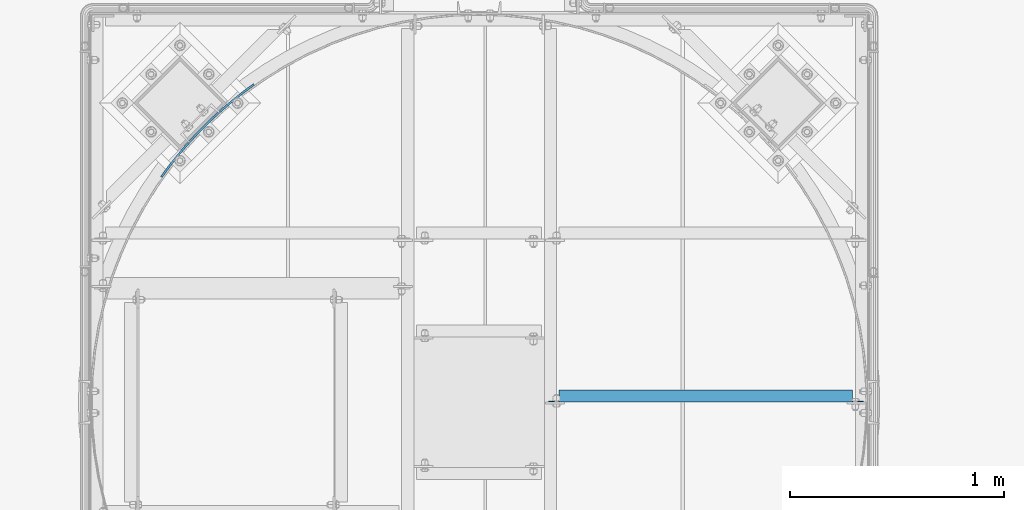
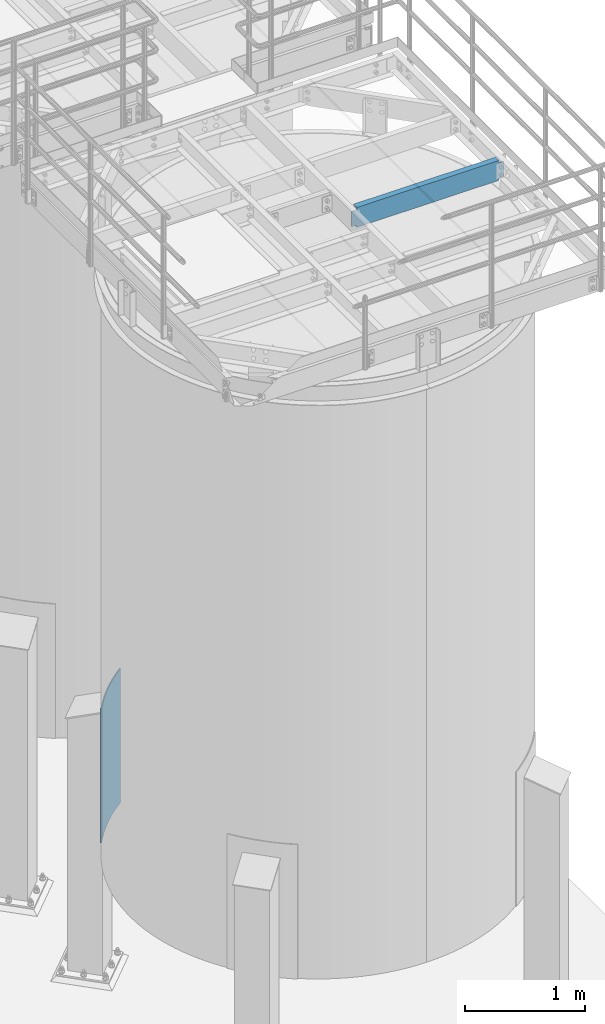
# One storey, part 922 of 1876: 2 beams, 2 elements without a shape of their own.
"""IFC2X3 building model written with IfcOpenShell, lengths in millimetres."""

from ifc_helpers import new_model, si_unit, frame, origin_with_axes, place, context, subcontext, project, spatial, faceted_brep, material, type_object, element, aggregate, save


model = new_model("IFC2X3")

# Units and contexts
model_context = context("Model", 3, precision=1e-05, world=origin_with_axes())
body_context = subcontext(model_context, "Body", "Model", "MODEL_VIEW")
ifc_project = project(units=[si_unit("LENGTHUNIT", "METRE", prefix="MILLI"), si_unit("AREAUNIT", "SQUARE_METRE"), si_unit("VOLUMEUNIT", "CUBIC_METRE"), si_unit("MASSUNIT", "GRAM", prefix="KILO"), si_unit("TIMEUNIT", "SECOND"), si_unit("PLANEANGLEUNIT", "RADIAN"), si_unit("SOLIDANGLEUNIT", "STERADIAN"), si_unit("THERMODYNAMICTEMPERATUREUNIT", "DEGREE_CELSIUS"), si_unit("LUMINOUSINTENSITYUNIT", "LUMEN")], contexts=[model_context])

# Site, building, storey
site_placement = place(None, origin_with_axes())
site = spatial("IfcSite", under=ifc_project, at=site_placement, CompositionType="ELEMENT")
building_placement = place(site_placement, origin_with_axes())
building = spatial("IfcBuilding", under=site, at=building_placement, Name="Undefined", CompositionType="ELEMENT")
storey_placement = place(building_placement, origin_with_axes())
storey = spatial("IfcBuildingStorey", under=building, at=storey_placement, Name="Undefined", CompositionType="ELEMENT", Elevation=0.0)

# Assembly, beam
assembly_1_placement = place(storey_placement, origin_with_axes())
assembly_1 = element("IfcElementAssembly", 1, at=assembly_1_placement, inside=storey, Name="BEAM", AssemblyPlace="NOTDEFINED", PredefinedType="RIGID_FRAME")
ifc_material = material(Name="STEEL/A36")
beam_type_1 = type_object("IfcBeamType", Name="C8X11.5", PredefinedType="NOTDEFINED")
beam_1_placement = place(assembly_1_placement, frame((5486.40143150122, -13560.3894287103, 7896.225), z_axis=(0.0, 0.0, -1.0), x_axis=(1.0, 0.0, 0.0)))
beam_1 = element("IfcBeam", 2, at=beam_1_placement, type_object=beam_type_1, material=ifc_material, Name="BEAM", ObjectType="C8X11.5", context=body_context, shape_type="Brep", body=[
    faceted_brep([(1441.44713699756, -28.5750000000007, -96.8355949999996), (1441.44713699756, -28.5750000000007, -101.6), (1441.44713699756, 28.5750000000007, -101.6), (1441.44713699756, 28.5750000000007, -88.899999809264), (1441.44713699756, 19.0576241940926, -88.899999809264), (1441.5521000322, 22.2250000000004, -88.3723149999996), (1442.41386692015, 28.5750000000007, -84.0399202912186), (1442.41386692015, 22.2250000000004, -84.0399202912186), (1445.16688082063, 28.5750000000007, -79.9197438230649), (1445.16688082063, 22.2250000000004, -79.9197438230649), (1449.28705728878, 28.5750000000007, -77.1667299225865), (1449.28705728878, 22.2250000000004, -77.1667299225865), (1454.14713680683, 28.5750000000007, -76.1999999999989), (1454.14713680683, 22.2250000000004, -76.1999999999989), (1492.24713699756, 22.2250000000004, -76.1999999999989), (1492.24713699756, 28.5750000000007, -76.1999999999989), (1441.44713699756, -28.5750000000007, 101.6), (1441.44713699756, 28.5750000000007, 101.6), (69.8500000000013, 28.5750000000007, 101.6), (69.8500000000013, -28.5750000000007, 101.6), (69.8500000000013, 19.0576241940817, -88.8999998092659), (69.8500000000013, 28.5750000000007, -88.8999998092659), (69.8500000000013, 28.5750000000007, -101.6), (69.8500000000013, -28.5750000000007, -101.6), (69.8500000000013, -28.5750000000007, -96.8355949999996), (69.7450369653598, 22.2250000000004, -88.3723149999996), (68.8832700774137, 22.2250000000004, -84.0399202912204), (68.8832700774137, 28.5750000000007, -84.0399202912204), (66.1302561769353, 22.2250000000004, -79.9197438230667), (66.1302561769353, 28.5750000000007, -79.9197438230667), (62.0100797087816, 22.2250000000004, -77.1667299225883), (62.0100797087816, 28.5750000000007, -77.1667299225883), (57.1500001907361, 22.2250000000004, -76.2000000000007), (57.1500001907361, 28.5750000000007, -76.2000000000007), (19.0499999999993, 22.2250000000004, -76.2000000000007), (19.0499999999993, 28.5750000000007, -76.2000000000007), (19.0499999999993, 22.2250000000004, 76.1999999999989), (19.0499999999993, 28.5750000000007, 76.1999999999989), (57.1500001907361, 22.2250000000004, 76.1999999999989), (57.1500001907361, 28.5750000000007, 76.1999999999989), (62.0100797087816, 22.2250000000004, 77.1667299225865), (62.0100797087816, 28.5750000000007, 77.1667299225865), (66.1302561769353, 22.2250000000004, 79.9197438230649), (66.1302561769353, 28.5750000000007, 79.9197438230649), (68.8832700774137, 22.2250000000004, 84.0399202912186), (68.8832700774137, 28.5750000000007, 84.0399202912186), (69.8500000000013, 19.0576241940926, 88.899999809264), (69.8500000000013, 28.5750000000007, 88.899999809264), (69.7450369653607, 22.2250000000004, 88.3723149999996), (69.8500000000013, -28.5750000000007, 96.8355949999996), (1441.44713699756, -28.5750000000007, 96.8355949999996), (1441.44713699756, 19.0576241940817, 88.8999998092659), (1441.44713699756, 28.5750000000007, 88.8999998092659), (1441.5521000322, 22.2250000000004, 88.3723149999996), (1442.41386692015, 22.2250000000004, 84.0399202912204), (1442.41386692015, 28.5750000000007, 84.0399202912204), (1445.16688082063, 22.2250000000004, 79.9197438230667), (1445.16688082063, 28.5750000000007, 79.9197438230667), (1449.28705728878, 22.2250000000004, 77.1667299225883), (1449.28705728878, 28.5750000000007, 77.1667299225883), (1454.14713680683, 22.2250000000004, 76.2000000000007), (1454.14713680683, 28.5750000000007, 76.2000000000007), (1492.24713699756, 22.2250000000004, 76.2000000000007), (1492.24713699756, 28.5750000000007, 76.2000000000007)], [[[0, 1, 2, 3, 4]], [[5, 4, 3, 6, 7]], [[7, 6, 8, 9]], [[9, 8, 10, 11]], [[11, 10, 12, 13]], [[14, 13, 12, 15]], [[16, 17, 18, 19]], [[20, 21, 22, 23, 24]], [[25, 26, 27, 21, 20]], [[28, 29, 27, 26]], [[30, 31, 29, 28]], [[32, 33, 31, 30]], [[34, 35, 33, 32]], [[36, 37, 35, 34]], [[38, 39, 37, 36]], [[40, 41, 39, 38]], [[42, 43, 41, 40]], [[44, 45, 43, 42]], [[46, 47, 45, 44, 48]], [[19, 18, 47, 46, 49]], [[50, 16, 19, 49]], [[16, 50, 51, 52, 17]], [[48, 53, 51, 50, 49, 46]], [[54, 55, 52, 51, 53]], [[56, 57, 55, 54]], [[58, 59, 57, 56]], [[60, 61, 59, 58]], [[62, 63, 61, 60]], [[63, 62, 14, 15]], [[29, 31, 33, 35, 37, 39, 41, 43, 45, 47, 18, 17, 52, 55, 57, 59, 61, 63, 15, 12, 10, 8, 6, 3, 2, 22, 21, 27]], [[2, 1, 23, 22]], [[1, 0, 24, 23]], [[24, 0, 4, 5, 25, 20]], [[5, 7, 9, 11, 13, 14, 62, 60, 58, 56, 54, 53, 48, 44, 42, 40, 38, 36, 34, 32, 30, 28, 26, 25]]]),
])
aggregate(assembly_1, [beam_1])

assembly_2_placement = place(storey_placement, origin_with_axes())
assembly_2 = element("IfcElementAssembly", 3, at=assembly_2_placement, inside=storey, Name="COLUMN", AssemblyPlace="NOTDEFINED", PredefinedType="RIGID_FRAME")
beam_type_2 = type_object("IfcBeamType", PredefinedType="NOTDEFINED")
beam_2_placement = place(assembly_2_placement, frame((4128.4104793459, -12103.6278020889, 2209.8), z_axis=(0.0, 0.0, 1.0), x_axis=(-0.707106781186547, -0.707106781186548, 0.0)))
beam_2 = element("IfcBeam", 4, at=beam_2_placement, type_object=beam_type_2, material=ifc_material, Name="PLATE", context=body_context, shape_type="Brep", body=[
    faceted_brep([(0.79930179960138, 4.69494652612411, -685.8), (0.79930179960138, 4.69494652612411, 685.8), (61.342263906226, -4.5647055990521, 685.8), (61.342263906226, -4.5647055990521, -685.8), (-0.799301799600926, -4.69494652612411, 685.8), (-0.799301799600926, -4.69494652612411, -685.8), (60.0611937621738, -14.003163327201, -685.8), (60.0611937621738, -14.003163327201, 685.8), (122.16302969072, -11.7776015161726, 685.8), (122.16302969072, -11.7776015161726, -685.8), (121.200950016122, -21.2538891700879, -685.8), (121.200950016122, -21.2538891700879, 685.8), (183.192425169105, -16.9355376990206, 685.8), (183.192425169105, -16.9355376990206, -685.8), (182.550430177147, -26.438877503022, -685.8), (182.550430177147, -26.438877503022, 685.8), (244.361039074185, -20.0326478124662, 685.8), (244.361039074185, -20.0326478124662, -685.8), (244.039858932445, -29.5522312233406, -685.8), (244.039858932445, -29.5522312233406, 685.8), (305.59930179986, -21.0654093844969, 685.8), (305.59930179986, -21.0654093844969, -685.8), (305.599301799861, -30.5904093844983, -685.8), (305.599301799861, -30.5904093844983, 685.8), (366.837564525536, -20.0326478124662, 685.8), (366.837564525536, -20.0326478124662, -685.8), (367.158744667275, -29.5522312233406, -685.8), (367.158744667275, -29.5522312233406, 685.8), (428.006178430616, -16.9355376990206, 685.8), (428.006178430616, -16.9355376990206, -685.8), (428.648173422574, -26.438877503022, -685.8), (428.648173422574, -26.438877503022, 685.8), (489.035573909001, -11.7776015161708, 685.8), (489.035573909001, -11.7776015161708, -685.8), (489.997653583599, -21.253889170086, -685.8), (489.997653583599, -21.253889170086, 685.8), (549.856339693495, -4.5647055990521, 685.8), (549.856339693495, -4.5647055990521, -685.8), (551.137409837547, -14.003163327201, -685.8), (551.137409837547, -14.003163327201, 685.8), (610.39930180012, 4.69494652612411, 685.8), (610.39930180012, 4.69494652612411, -685.8), (611.997905399323, -4.69494652612229, 685.8), (611.997905399323, -4.69494652612229, -685.8)], [[[0, 1, 2, 3]], [[4, 5, 6, 7]], [[5, 4, 1, 0]], [[3, 2, 8, 9]], [[7, 6, 10, 11]], [[9, 8, 12, 13]], [[11, 10, 14, 15]], [[13, 12, 16, 17]], [[15, 14, 18, 19]], [[17, 16, 20, 21]], [[19, 18, 22, 23]], [[21, 20, 24, 25]], [[23, 22, 26, 27]], [[25, 24, 28, 29]], [[27, 26, 30, 31]], [[29, 28, 32, 33]], [[31, 30, 34, 35]], [[33, 32, 36, 37]], [[35, 34, 38, 39]], [[37, 36, 40, 41]], [[36, 32, 28, 24, 20, 16, 12, 8, 2, 1, 4, 7, 11, 15, 19, 23, 27, 31, 35, 39, 42, 40]], [[39, 38, 43, 42]], [[38, 34, 30, 26, 22, 18, 14, 10, 6, 5, 0, 3, 9, 13, 17, 21, 25, 29, 33, 37, 41, 43]], [[42, 43, 41, 40]]]),
])
aggregate(assembly_2, [beam_2])

save(model, "model.ifc")
